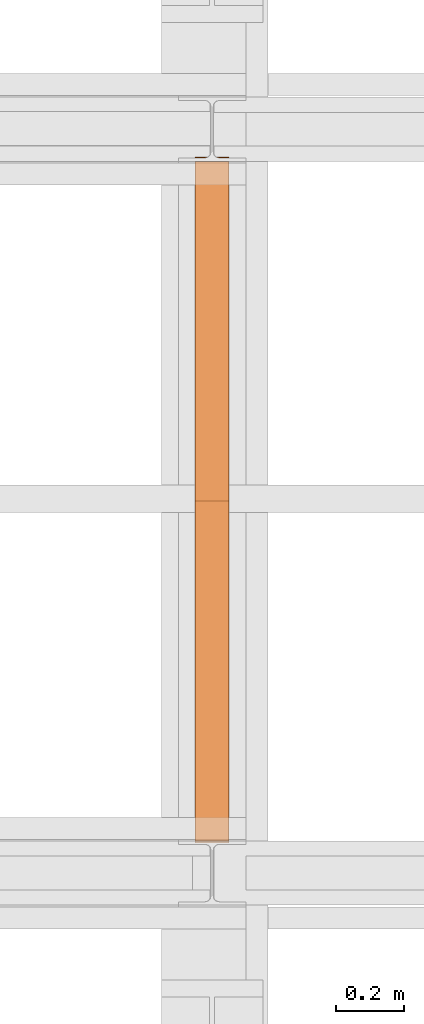
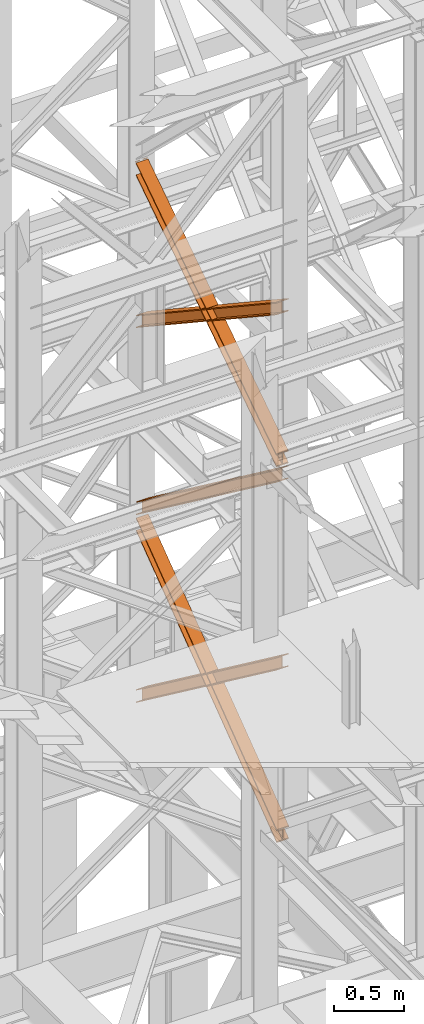
# One storey, part 122 of 208: 5 proxies.
"""IFC2X3 building model written with IfcOpenShell, lengths in millimetres."""

from ifc_helpers import new_model, entity, si_unit, converted_unit, frame, origin, origin_with_axes, place, context, subcontext, project, spatial, faceted_brep, element, save


model = new_model("IFC2X3")

# Units and contexts
model_context = context("Model", 3, precision=1e-05, world=origin())
plan_context = context("Plan", 3, precision=1e-05, world=origin())
body_context = subcontext(model_context, "Body", "Model", "MODEL_VIEW")
ifc_project = project(units=[si_unit("LENGTHUNIT", "METRE", prefix="MILLI"), converted_unit("PLANEANGLEUNIT", "DEGREE", entity("IfcPlaneAngleMeasure", 0.0174532925199433), si_unit("PLANEANGLEUNIT", "RADIAN"), dimensions=[0, 0, 0, 0, 0, 0, 0]), si_unit("AREAUNIT", "SQUARE_METRE"), si_unit("VOLUMEUNIT", "CUBIC_METRE")], contexts=[model_context, plan_context])

# Building, storey
building_placement = place(None, origin())
building = spatial("IfcBuilding", under=ifc_project, at=building_placement, CompositionType="COMPLEX")
storey_placement = place(building_placement, origin_with_axes())
storey = spatial("IfcBuildingStorey", under=building, at=storey_placement, Name="Geschoss", CompositionType="ELEMENT")

# Proxies
proxy_1_placement = place(storey_placement, frame((2142.708285590094, -15867.5743840594, 8785.68637815495), z_axis=(0.0, 0.0, 1.0), x_axis=(1.0, 0.0, 0.0)))
element("IfcBuildingElementProxy", 1, at=proxy_1_placement, inside=storey, context=body_context, shape_type="Brep", body=[
    faceted_brep([(100.0233329519015, 2010.009987483023, 1330.225167941017), (100.1729351296908, 0.00999999999839929, 0.02100513656660041), (100.1718996660056, 0.00999999999839929, 9.435622162609434), (100.0222968606722, 2010.009987483023, 1339.639782821612), (0.0233335574685043, 2010.009987483023, 1330.214162804454), (0.1729357352560328, 0.00999999999839929, 0.01000000000021828), (100.1729351296908, 0.00999999999839929, 0.02100513656660041), (100.0233329519015, 2010.009987483023, 1330.225167941017), (0.02229746624107065, 2010.009987483023, 1339.628777685057), (0.1719002715708484, 0.00999999999839929, 9.424617026043052), (0.1729357352560328, 0.00999999999839929, 0.01000000000021828), (0.0233335574685043, 2010.009987483023, 1330.214162804454), (47.52229717859518, 2010.009987483023, 1339.634005124923), (47.67189998392678, 0.00999999999839929, 9.429844465905262), (0.1719002715708484, 0.00999999999839929, 9.424617026043052), (0.02229746624107065, 2010.009987483023, 1339.628777685057), (47.5119362662881, 2010.009987483023, 1433.780153930935), (47.66154536059003, 0.00999999999839929, 103.5760147725105), (47.67189998392678, 0.00999999999839929, 9.429844465905262), (47.52229717859518, 2010.009987483023, 1339.634005124923), (0.01106478197652905, 2021.979642245309, 1441.696427017001), (0.01120823570636276, 2020.00998539686, 1440.39291091142), (29.30668085241086, 2020.00998539686, 1440.396134918205), (38.62249288135536, 2021.874530444144, 1441.631113415808), (38.72760466098953, 2021.979642245309, 1441.70068782511), (47.5119362662881, 2010.009987483023, 1433.780153930935), (0.01193655393217341, 2010.009987483023, 1433.774926491073), (0.161545648234096, 0.00999999999839929, 103.5707873326446), (47.66154536059003, 0.00999999999839929, 103.5760147725105), (0.01000000000021828, 2022.373573614999, 1451.371745118717), (0.01017214447529113, 2020.00998539686, 1449.807525792019), (0.01120823570636276, 2020.00998539686, 1440.39291091142), (0.01106478197652905, 2021.979642245309, 1441.696427017001), (0.01193655393217341, 2010.009987483023, 1433.774926491073), (0.01090046270292078, 2010.009987483023, 1443.189541371672), (0.1605101872537489, 0.00999999999839929, 112.9854043679352), (0.161545648234096, 0.00999999999839929, 103.5707873326446), (100.0099993944386, 2022.373573614997, 1451.382750255283), (100.0101715389137, 2020.00998539686, 1449.818530928586), (71.806685024736, 2020.00998539686, 1449.815427096359), (62.49087299579151, 2021.874530444144, 1451.048355158282), (61.99182992716487, 2022.373573614999, 1451.378566303787), (0.01090046270292078, 2010.009987483023, 1443.189541371672), (100.0108998571395, 2010.009987483023, 1443.200546508238), (100.1605095816922, 0.00999999999839929, 112.9964095044979), (0.1605101872537489, 0.00999999999839929, 112.9854043679352), (0.01017214447529113, 2020.00998539686, 1449.807525792019), (0.01000000000021828, 2022.373573614999, 1451.371745118717), (39.12153594998017, 2022.373573614999, 1451.376049396686), (38.62249288135536, 2021.874530444144, 1451.045728410436), (29.30668085241086, 2020.00998539686, 1449.810749912833), (100.0110641764131, 2021.979642245307, 1441.707432153557), (100.0112076301411, 2020.00998539686, 1440.403916047975), (100.0101715389137, 2020.00998539686, 1449.818530928586), (100.0099993944386, 2022.373573614997, 1451.382750255283), (100.0108998571395, 2010.009987483023, 1443.200546508238), (100.0119359483706, 2010.009987483023, 1433.785931627628), (100.1615450426671, 0.00999999999839929, 103.5817924692037), (100.1605095816922, 0.00999999999839929, 112.9964095044979), (52.51193623601102, 2010.009987483023, 1433.780704187766), (52.66154533031295, 0.00999999999839929, 103.5765650293379), (100.1615450426671, 0.00999999999839929, 103.5817924692037), (100.0119359483706, 2010.009987483023, 1433.785931627628), (71.806685024736, 2020.00998539686, 1440.400812101727), (100.0112076301411, 2020.00998539686, 1440.403916047975), (100.0110641764131, 2021.979642245307, 1441.707432153557), (62.38576121615733, 2021.979642245309, 1441.703291437565), (62.49087299579151, 2021.874530444144, 1441.63374016365), (52.52229714831447, 2010.009987483023, 1339.63455538175), (52.67189995364788, 0.00999999999839929, 9.43039472273631), (52.66154533031295, 0.00999999999839929, 103.5765650293379), (52.51193623601102, 2010.009987483023, 1433.780704187766), (100.0222968606722, 2010.009987483023, 1339.639782821612), (100.1718996660056, 0.00999999999839929, 9.435622162609434), (52.67189995364788, 0.00999999999839929, 9.43039472273631), (52.52229714831447, 2010.009987483023, 1339.63455538175), (62.38576121615733, 2021.979642245309, 1441.703291437565), (100.0110641764131, 2021.979642245307, 1441.707432153557), (100.0099993944386, 2022.373573614997, 1451.382750255283), (61.99182992716487, 2022.373573614999, 1451.378566303787), (39.12153594998017, 2022.373573614999, 1451.376049396686), (0.01000000000021828, 2022.373573614999, 1451.371745118717), (0.01106478197652905, 2021.979642245309, 1441.696427017001), (38.72760466098953, 2021.979642245309, 1441.70068782511), (62.49087299579151, 2021.874530444144, 1441.63374016365), (62.38576121615733, 2021.979642245309, 1441.703291437565), (61.99182992716487, 2022.373573614999, 1451.378566303787), (62.49087299579151, 2021.874530444144, 1451.048355158282), (62.49087299579151, 2021.874530444144, 1451.048355158282), (71.806685024736, 2020.00998539686, 1449.815427096359), (71.806685024736, 2020.00998539686, 1440.400812101727), (62.49087299579151, 2021.874530444144, 1441.63374016365), (71.806685024736, 2020.00998539686, 1449.815427096359), (100.0101715389137, 2020.00998539686, 1449.818530928586), (100.0112076301411, 2020.00998539686, 1440.403916047975), (71.806685024736, 2020.00998539686, 1440.400812101727), (100.0222968606722, 2010.009987483023, 1339.639782821612), (52.52229714831447, 2010.009987483023, 1339.63455538175), (52.51193623601102, 2010.009987483023, 1433.780704187766), (100.0119359483706, 2010.009987483023, 1433.785931627628), (100.0108998571395, 2010.009987483023, 1443.200546508238), (0.01090046270292078, 2010.009987483023, 1443.189541371672), (0.01193655393217341, 2010.009987483023, 1433.774926491073), (47.5119362662881, 2010.009987483023, 1433.780153930935), (47.52229717859518, 2010.009987483023, 1339.634005124923), (0.02229746624107065, 2010.009987483023, 1339.628777685057), (0.0233335574685043, 2010.009987483023, 1330.214162804454), (100.0233329519015, 2010.009987483023, 1330.225167941017), (29.30668085241086, 2020.00998539686, 1440.396134918205), (0.01120823570636276, 2020.00998539686, 1440.39291091142), (0.01017214447529113, 2020.00998539686, 1449.807525792019), (29.30668085241086, 2020.00998539686, 1449.810749912833), (29.30668085241086, 2020.00998539686, 1449.810749912833), (38.62249288135536, 2021.874530444144, 1451.045728410436), (38.62249288135536, 2021.874530444144, 1441.631113415808), (29.30668085241086, 2020.00998539686, 1440.396134918205), (38.62249288135536, 2021.874530444144, 1451.045728410436), (39.12153594998017, 2022.373573614999, 1451.376049396686), (38.72760466098953, 2021.979642245309, 1441.70068782511), (38.62249288135536, 2021.874530444144, 1441.631113415808), (100.1729351296908, 0.00999999999839929, 0.02100513656660041), (0.1729357352560328, 0.00999999999839929, 0.01000000000021828), (0.1719002715708484, 0.00999999999839929, 9.424617026043052), (47.67189998392678, 0.00999999999839929, 9.429844465905262), (47.66154536059003, 0.00999999999839929, 103.5760147725105), (0.161545648234096, 0.00999999999839929, 103.5707873326446), (0.1605101872537489, 0.00999999999839929, 112.9854043679352), (100.1605095816922, 0.00999999999839929, 112.9964095044979), (100.1615450426671, 0.00999999999839929, 103.5817924692037), (52.66154533031295, 0.00999999999839929, 103.5765650293379), (52.67189995364788, 0.00999999999839929, 9.43039472273631), (100.1718996660056, 0.00999999999839929, 9.435622162609434)], [[[0, 1, 2, 3]], [[4, 5, 6, 7]], [[8, 9, 10, 11]], [[12, 13, 14, 15]], [[16, 17, 18, 19]], [[20, 21, 22, 23, 24]], [[25, 26, 27, 28]], [[29, 30, 31, 32]], [[33, 34, 35, 36]], [[37, 38, 39, 40, 41]], [[42, 43, 44, 45]], [[46, 47, 48, 49, 50]], [[51, 52, 53, 54]], [[55, 56, 57, 58]], [[59, 60, 61, 62]], [[63, 64, 65, 66, 67]], [[68, 69, 70, 71]], [[72, 73, 74, 75]], [[76, 77, 78, 79]], [[80, 81, 82, 83]], [[84, 85, 86, 87]], [[88, 89, 90, 91]], [[92, 93, 94, 95]], [[96, 97, 98, 99, 100, 101, 102, 103, 104, 105, 106, 107]], [[108, 109, 110, 111]], [[112, 113, 114, 115]], [[116, 117, 118, 119]], [[120, 121, 122, 123, 124, 125, 126, 127, 128, 129, 130, 131]]], orient=[[False], [False], [False], [False], [False], [False], [False], [False], [False], [False], [False], [False], [False], [False], [False], [False], [False], [False], [False], [False], [False], [False], [False], [False], [False], [False], [False], [False]]),
])
proxy_2_placement = place(storey_placement, frame((2142.717760907841, -15867.5743840594, 8785.050753356181), z_axis=(0.0, 0.0, 1.0), x_axis=(1.0, 0.0, 0.0)))
element("IfcBuildingElementProxy", 2, at=proxy_2_placement, inside=storey, context=body_context, shape_type="Brep", body=[
    faceted_brep([(100.0213960296205, 0.01000000000021828, 1340.168495796863), (100.1712583843328, 2010.009987483025, 9.436734304987112), (100.1722939377632, 2010.009987483025, 0.02100513655932446), (100.0224320873658, 0.01000000000021828, 1330.752768748162), (100.0224320873658, 0.01000000000021828, 1330.752768748162), (100.1722939377632, 2010.009987483025, 0.02100513655932446), (0.1722945433284622, 2010.009987483025, 0.01000000000021828), (0.02243269293285266, 0.01000000000021828, 1330.741763611606), (0.02243269293285266, 0.01000000000021828, 1330.741763611606), (0.1722945433284622, 2010.009987483025, 0.01000000000021828), (0.1712589898997976, 2010.009987483025, 9.425729168431644), (0.02139663518937596, 0.01000000000021828, 1340.1574906603), (0.02139663518937596, 0.01000000000021828, 1340.1574906603), (0.1712589898997976, 2010.009987483025, 9.425729168431644), (47.67125870225755, 2010.009987483025, 9.430956608297492), (47.52139634754713, 0.01000000000021828, 1340.162718100166), (47.52139634754713, 0.01000000000021828, 1340.162718100166), (47.67125870225755, 2010.009987483025, 9.430956608297492), (47.66090317872477, 2010.009987483025, 103.5882483377918), (47.51103577010144, 0.01000000000021828, 1434.319988587145), (47.51103577010144, 0.01000000000021828, 1434.319988587145), (47.66090317872477, 2010.009987483025, 103.5882483377918), (0.1609034663688362, 2010.009987483025, 103.583020897926), (0.01103605774551397, 0.01000000000021828, 1434.31476114728), (0.01103605774551397, 0.01000000000021828, 1434.31476114728), (0.1609034663688362, 2010.009987483025, 103.583020897926), (0.1598679150920361, 2010.009987483025, 112.998750075405), (0.01000000000021828, 0.01000000000021828, 1443.730488195981), (0.01000000000021828, 0.01000000000021828, 1443.730488195981), (0.1598679150920361, 2010.009987483025, 112.998750075405), (100.159867309525, 2010.009987483025, 113.0097552119678), (100.009999394435, 0.01000000000021828, 1443.741493332544), (100.009999394435, 0.01000000000021828, 1443.741493332544), (100.159867309525, 2010.009987483025, 113.0097552119678), (100.1609028608018, 2010.009987483025, 103.5940260344851), (100.0110354521785, 0.01000000000021828, 1434.325766283846), (100.0110354521785, 0.01000000000021828, 1434.325766283846), (100.1609028608018, 2010.009987483025, 103.5940260344851), (52.66090314844587, 2010.009987483025, 103.5887985946229), (52.51103573982437, 0.01000000000021828, 1434.320538843973), (52.51103573982437, 0.01000000000021828, 1434.320538843973), (52.66090314844587, 2010.009987483025, 103.5887985946229), (52.67125867197683, 2010.009987483025, 9.431506865121264), (52.52139631726823, 0.01000000000021828, 1340.163268357001), (52.52139631726823, 0.01000000000021828, 1340.163268357001), (52.67125867197683, 2010.009987483025, 9.431506865121264), (100.1712583843328, 2010.009987483025, 9.436734304987112), (100.0213960296205, 0.01000000000021828, 1340.168495796863), (100.0224320873658, 0.01000000000021828, 1330.752768748162), (0.02243269293285266, 0.01000000000021828, 1330.741763611606), (0.02139663518937596, 0.01000000000021828, 1340.1574906603), (47.52139634754713, 0.01000000000021828, 1340.162718100166), (47.51103577010144, 0.01000000000021828, 1434.319988587145), (0.01103605774551397, 0.01000000000021828, 1434.31476114728), (0.01000000000021828, 0.01000000000021828, 1443.730488195981), (100.009999394435, 0.01000000000021828, 1443.741493332544), (100.0110354521785, 0.01000000000021828, 1434.325766283846), (52.51103573982437, 0.01000000000021828, 1434.320538843973), (52.52139631726823, 0.01000000000021828, 1340.163268357001), (100.0213960296205, 0.01000000000021828, 1340.168495796863), (100.1712583843328, 2010.009987483025, 9.436734304987112), (52.67125867197683, 2010.009987483025, 9.431506865121264), (52.66090314844587, 2010.009987483025, 103.5887985946229), (100.1609028608018, 2010.009987483025, 103.5940260344851), (100.159867309525, 2010.009987483025, 113.0097552119678), (0.1598679150920361, 2010.009987483025, 112.998750075405), (0.1609034663688362, 2010.009987483025, 103.583020897926), (47.66090317872477, 2010.009987483025, 103.5882483377918), (47.67125870225755, 2010.009987483025, 9.430956608297492), (0.1712589898997976, 2010.009987483025, 9.425729168431644), (0.1722945433284622, 2010.009987483025, 0.01000000000021828), (100.1722939377632, 2010.009987483025, 0.02100513655932446)], [[[0, 1, 2, 3]], [[4, 5, 6, 7]], [[8, 9, 10, 11]], [[12, 13, 14, 15]], [[16, 17, 18, 19]], [[20, 21, 22, 23]], [[24, 25, 26, 27]], [[28, 29, 30, 31]], [[32, 33, 34, 35]], [[36, 37, 38, 39]], [[40, 41, 42, 43]], [[44, 45, 46, 47]], [[48, 49, 50, 51, 52, 53, 54, 55, 56, 57, 58, 59]], [[60, 61, 62, 63, 64, 65, 66, 67, 68, 69, 70, 71]]], orient=[[False], [False], [False], [False], [False], [False], [False], [False], [False], [False], [False], [False], [False], [False]]),
])
proxy_3_placement = place(storey_placement, frame((2143.082798491103, -15873.1965123697, 5499.689768811883), z_axis=(0.0, 0.0, 1.0), x_axis=(1.0, 0.0, 0.0)))
element("IfcBuildingElementProxy", 3, at=proxy_3_placement, inside=storey, context=body_context, shape_type="Brep", body=[
    faceted_brep([(100.0229428112289, 2015.632115793322, 1505.703241650141), (100.1858455764686, 1.953628280809426, 0.02100513656296243), (100.1847800613887, 1.791659257409265, 9.702984703128095), (100.0218641931642, 2015.632115793322, 1515.50632986583), (0.02294341679771605, 2015.632115793322, 1505.692236513578), (0.1858461820338562, 1.953628280809426, 0.01000000000021828), (100.1858455764686, 1.953628280809426, 0.02100513656296243), (100.0229428112289, 2015.632115793322, 1505.703241650141), (0.02186479873125791, 2015.632115793322, 1515.495324729271), (0.1847806669538841, 1.791659257407446, 9.691979566568989), (0.1858461820338562, 1.953628280809426, 0.01000000000021828), (0.02294341679771605, 2015.632115793322, 1505.692236513578), (47.52186451108355, 2015.632115793322, 1515.500552169136), (47.68478037930981, 1.791659257407446, 9.697207006434837), (0.1847806669538841, 1.791659257407446, 9.691979566568989), (0.02186479873125791, 2015.632115793322, 1515.495324729271), (47.51107833042624, 2015.632115793322, 1613.531434326045), (47.67412522851737, 0.1719690234003792, 106.517002672068), (47.68478037930981, 1.791659257407446, 9.697207006434837), (47.52186451108355, 2015.632115793322, 1515.500552169136), (0.01107861806849542, 2015.632115793322, 1613.526206886179), (0.174125516157801, 0.1719690234003792, 106.5117752322021), (47.67412522851737, 0.1719690234003792, 106.517002672068), (47.51107833042624, 2015.632115793322, 1613.531434326045), (0.01000000000021828, 2015.632115793322, 1623.329295101868), (0.1730600010778289, 0.01000000000021828, 116.1937547987636), (0.174125516157801, 0.1719690234003792, 106.5117752322021), (0.01107861806849542, 2015.632115793322, 1613.526206886179), (100.0099993944386, 2015.632115793322, 1623.340300238435), (100.1730593955126, 0.01000000000203727, 116.2047599353264), (0.1730600010778289, 0.01000000000021828, 116.1937547987636), (0.01000000000021828, 2015.632115793322, 1623.329295101868), (100.0110780125051, 2015.632115793322, 1613.537212022739), (100.1741249105908, 0.1719690234003792, 106.5227803687612), (100.1730593955126, 0.01000000000203727, 116.2047599353264), (100.0099993944386, 2015.632115793322, 1623.340300238435), (52.51107830014917, 2015.632115793322, 1613.531984582873), (52.67412519823665, 0.1719690234003792, 106.5175529288954), (100.1741249105908, 0.1719690234003792, 106.5227803687612), (100.0110780125051, 2015.632115793322, 1613.537212022739), (52.52186448080829, 2015.632115793322, 1515.501102425964), (52.68478034903274, 1.791659257409265, 9.697757263262247), (52.67412519823665, 0.1719690234003792, 106.5175529288954), (52.51107830014917, 2015.632115793322, 1613.531984582873), (100.0218641931642, 2015.632115793322, 1515.50632986583), (100.1847800613887, 1.791659257409265, 9.702984703128095), (52.68478034903274, 1.791659257409265, 9.697757263262247), (52.52186448080829, 2015.632115793322, 1515.501102425964), (100.1858455764686, 1.953628280809426, 0.02100513656296243), (0.1858461820338562, 1.953628280809426, 0.01000000000021828), (0.1847806669538841, 1.791659257407446, 9.691979566568989), (47.68478037930981, 1.791659257407446, 9.697207006434837), (47.67412522851737, 0.1719690234003792, 106.517002672068), (0.174125516157801, 0.1719690234003792, 106.5117752322021), (0.1730600010778289, 0.01000000000021828, 116.1937547987636), (100.1730593955126, 0.01000000000203727, 116.2047599353264), (100.1741249105908, 0.1719690234003792, 106.5227803687612), (52.67412519823665, 0.1719690234003792, 106.5175529288954), (52.68478034903274, 1.791659257409265, 9.697757263262247), (100.1847800613887, 1.791659257409265, 9.702984703128095), (100.0218641931642, 2015.632115793322, 1515.50632986583), (52.52186448080829, 2015.632115793322, 1515.501102425964), (52.51107830014917, 2015.632115793322, 1613.531984582873), (100.0110780125051, 2015.632115793322, 1613.537212022739), (100.0099993944386, 2015.632115793322, 1623.340300238435), (0.01000000000021828, 2015.632115793322, 1623.329295101868), (0.01107861806849542, 2015.632115793322, 1613.526206886179), (47.51107833042624, 2015.632115793322, 1613.531434326045), (47.52186451108355, 2015.632115793322, 1515.500552169136), (0.02186479873125791, 2015.632115793322, 1515.495324729271), (0.02294341679771605, 2015.632115793322, 1505.692236513578), (100.0229428112289, 2015.632115793322, 1505.703241650141)], [[[0, 1, 2, 3]], [[4, 5, 6, 7]], [[8, 9, 10, 11]], [[12, 13, 14, 15]], [[16, 17, 18, 19]], [[20, 21, 22, 23]], [[24, 25, 26, 27]], [[28, 29, 30, 31]], [[32, 33, 34, 35]], [[36, 37, 38, 39]], [[40, 41, 42, 43]], [[44, 45, 46, 47]], [[48, 49, 50, 51, 52, 53, 54, 55, 56, 57, 58, 59]], [[60, 61, 62, 63, 64, 65, 66, 67, 68, 69, 70, 71]]], orient=[[False], [False], [False], [False], [False], [False], [False], [False], [False], [False], [False], [False], [False], [False]]),
])
proxy_4_placement = place(storey_placement, frame((2143.082676642578, -15867.5743840594, 5504.219540188055), z_axis=(0.0, 0.0, 1.0), x_axis=(1.0, 0.0, 0.0)))
element("IfcBuildingElementProxy", 4, at=proxy_4_placement, inside=storey, context=body_context, shape_type="Brep", body=[
    faceted_brep([(100.0218596475406, 0.01000000000021828, 1511.076608371926), (100.1844513161013, 2010.009987483025, 9.820176864343011), (100.1855295209298, 2010.009987483025, 0.02100513655932446), (100.0229378523673, 0.01000000000021828, 1501.277436644132), (100.0229378523673, 0.01000000000021828, 1501.277436644132), (100.1855295209298, 2010.009987483025, 0.02100513655932446), (0.1855301264913578, 2010.009987483025, 0.01000000000021828), (0.02293845793246874, 0.01000000000021828, 1501.266431507576), (0.02293845793246874, 0.01000000000021828, 1501.266431507576), (0.1855301264913578, 2010.009987483025, 0.01000000000021828), (0.1844519216665503, 2010.009987483025, 9.809171727787543), (0.02186025310402329, 0.01000000000021828, 1511.06560323536), (0.02186025310402329, 0.01000000000021828, 1511.06560323536), (0.1844519216665503, 2010.009987483025, 9.809171727787543), (47.6844516340243, 2010.009987483025, 9.814399167646116), (47.52185996546359, 0.01000000000021828, 1511.070830675226), (47.52185996546359, 0.01000000000021828, 1511.070830675226), (47.6844516340243, 2010.009987483025, 9.814399167646116), (47.6736695857453, 2010.009987483025, 107.8061164454975), (47.51107791718459, 0.01000000000021828, 1609.062547953077), (47.51107791718459, 0.01000000000021828, 1609.062547953077), (47.6736695857453, 2010.009987483025, 107.8061164454975), (0.1736698733893718, 2010.009987483025, 107.8008890056317), (0.01107820482866373, 0.01000000000021828, 1609.057320513211), (0.01107820482866373, 0.01000000000021828, 1609.057320513211), (0.1736698733893718, 2010.009987483025, 107.8008890056317), (0.1725916685609263, 2010.009987483025, 117.6000607334227), (0.01000000000021828, 0.01000000000021828, 1618.856492240995), (0.01000000000021828, 0.01000000000021828, 1618.856492240995), (0.1725916685609263, 2010.009987483025, 117.6000607334227), (100.1725910629975, 2010.009987483025, 117.6110658699781), (100.009999394435, 0.01000000000021828, 1618.867497377558), (100.009999394435, 0.01000000000021828, 1618.867497377558), (100.1725910629975, 2010.009987483025, 117.6110658699781), (100.1736692678242, 2010.009987483025, 107.8118941421981), (100.0110775992634, 0.01000000000021828, 1609.068325649774), (100.0110775992634, 0.01000000000021828, 1609.068325649774), (100.1736692678242, 2010.009987483025, 107.8118941421981), (52.67366955546459, 2010.009987483025, 107.806666702325), (52.51107788690388, 0.01000000000021828, 1609.063098209905), (52.51107788690388, 0.01000000000021828, 1609.063098209905), (52.67366955546459, 2010.009987483025, 107.806666702325), (52.6844516037454, 2010.009987483025, 9.814949424477163), (52.52185993518287, 0.01000000000021828, 1511.071380932057), (52.52185993518287, 0.01000000000021828, 1511.071380932057), (52.6844516037454, 2010.009987483025, 9.814949424477163), (100.1844513161013, 2010.009987483025, 9.820176864343011), (100.0218596475406, 0.01000000000021828, 1511.076608371926), (100.1844513161013, 2010.009987483025, 9.820176864343011), (52.6844516037454, 2010.009987483025, 9.814949424477163), (52.67366955546459, 2010.009987483025, 107.806666702325), (100.1736692678242, 2010.009987483025, 107.8118941421981), (100.1725910629975, 2010.009987483025, 117.6110658699781), (0.1725916685609263, 2010.009987483025, 117.6000607334227), (0.1736698733893718, 2010.009987483025, 107.8008890056317), (47.6736695857453, 2010.009987483025, 107.8061164454975), (47.6844516340243, 2010.009987483025, 9.814399167646116), (0.1844519216665503, 2010.009987483025, 9.809171727787543), (0.1855301264913578, 2010.009987483025, 0.01000000000021828), (100.1855295209298, 2010.009987483025, 0.02100513655932446), (100.0229378523673, 0.01000000000021828, 1501.277436644132), (0.02293845793246874, 0.01000000000021828, 1501.266431507576), (0.02186025310402329, 0.01000000000021828, 1511.06560323536), (47.52185996546359, 0.01000000000021828, 1511.070830675226), (47.51107791718459, 0.01000000000021828, 1609.062547953077), (0.01107820482866373, 0.01000000000021828, 1609.057320513211), (0.01000000000021828, 0.01000000000021828, 1618.856492240995), (100.009999394435, 0.01000000000021828, 1618.867497377558), (100.0110775992634, 0.01000000000021828, 1609.068325649774), (52.51107788690388, 0.01000000000021828, 1609.063098209905), (52.52185993518287, 0.01000000000021828, 1511.071380932057), (100.0218596475406, 0.01000000000021828, 1511.076608371926)], [[[0, 1, 2, 3]], [[4, 5, 6, 7]], [[8, 9, 10, 11]], [[12, 13, 14, 15]], [[16, 17, 18, 19]], [[20, 21, 22, 23]], [[24, 25, 26, 27]], [[28, 29, 30, 31]], [[32, 33, 34, 35]], [[36, 37, 38, 39]], [[40, 41, 42, 43]], [[44, 45, 46, 47]], [[48, 49, 50, 51, 52, 53, 54, 55, 56, 57, 58, 59]], [[60, 61, 62, 63, 64, 65, 66, 67, 68, 69, 70, 71]]], orient=[[False], [False], [False], [False], [False], [False], [False], [False], [False], [False], [False], [False], [False], [False]]),
])
proxy_5_placement = place(storey_placement, frame((2142.895475356376, -15867.5743840594, 7147.441290649187), z_axis=(0.0, 0.0, 1.0), x_axis=(1.0, 0.0, 0.0)))
element("IfcBuildingElementProxy", 5, at=proxy_5_placement, inside=storey, context=body_context, shape_type="Brep", body=[
    faceted_brep([(100.0218623025612, 0.01000000000021828, 1512.063556389601), (100.1844166626906, 2010.009987483025, 9.822513400360549), (100.1854951088862, 2010.009987483025, 0.02100513655932446), (100.022940748755, 0.01000000000021828, 1502.262048125804), (100.022940748755, 0.01000000000021828, 1502.262048125804), (100.1854951088862, 2010.009987483025, 0.02100513655932446), (0.1854957144514629, 2010.009987483025, 0.01000000000021828), (0.02294135431839095, 0.01000000000021828, 1502.251042989237), (0.02294135431839095, 0.01000000000021828, 1502.251042989237), (0.1854957144514629, 2010.009987483025, 0.01000000000021828), (0.1844172682558565, 2010.009987483025, 9.811508263797805), (0.02186290812642255, 0.01000000000021828, 1512.052551253039), (0.02186290812642255, 0.01000000000021828, 1512.052551253039), (0.1844172682558565, 2010.009987483025, 9.811508263797805), (47.68441698061361, 2010.009987483025, 9.816735703663653), (47.52186262048235, 0.01000000000021828, 1512.057778692908), (47.52186262048235, 0.01000000000021828, 1512.057778692908), (47.68441698061361, 2010.009987483025, 9.816735703663653), (47.67363251868483, 2010.009987483025, 107.8318183416577), (47.51107815855175, 0.01000000000021828, 1610.072861330906), (47.51107815855175, 0.01000000000021828, 1610.072861330906), (47.67363251868483, 2010.009987483025, 107.8318183416577), (0.1736328063252586, 2010.009987483025, 107.8265909017955), (0.01107844619582465, 0.01000000000021828, 1610.067633891033), (0.01107844619582465, 0.01000000000021828, 1610.067633891033), (0.1736328063252586, 2010.009987483025, 107.8265909017955), (0.1725543601314712, 2010.009987483025, 117.6280991655931), (0.01000000000021828, 0.01000000000021828, 1619.86914215483), (0.01000000000021828, 0.01000000000021828, 1619.86914215483), (0.1725543601314712, 2010.009987483025, 117.6280991655931), (100.1725537545663, 2010.009987483025, 117.6391043021558), (100.009999394435, 0.01000000000021828, 1619.880147291397), (100.009999394435, 0.01000000000021828, 1619.880147291397), (100.1725537545663, 2010.009987483025, 117.6391043021558), (100.1736322007619, 2010.009987483025, 107.8375960383546), (100.0110778406306, 0.01000000000021828, 1610.078639027603), (100.0110778406306, 0.01000000000021828, 1610.078639027603), (100.1736322007619, 2010.009987483025, 107.8375960383546), (52.67363248840411, 2010.009987483025, 107.8323685984888), (52.51107812827468, 0.01000000000021828, 1610.073411587733), (52.51107812827468, 0.01000000000021828, 1610.073411587733), (52.67363248840411, 2010.009987483025, 107.8323685984888), (52.68441695033471, 2010.009987483025, 9.817285960491063), (52.52186259020346, 0.01000000000021828, 1512.058328949732), (52.52186259020346, 0.01000000000021828, 1512.058328949732), (52.68441695033471, 2010.009987483025, 9.817285960491063), (100.1844166626906, 2010.009987483025, 9.822513400360549), (100.0218623025612, 0.01000000000021828, 1512.063556389601), (100.1844166626906, 2010.009987483025, 9.822513400360549), (52.68441695033471, 2010.009987483025, 9.817285960491063), (52.67363248840411, 2010.009987483025, 107.8323685984888), (100.1736322007619, 2010.009987483025, 107.8375960383546), (100.1725537545663, 2010.009987483025, 117.6391043021558), (0.1725543601314712, 2010.009987483025, 117.6280991655931), (0.1736328063252586, 2010.009987483025, 107.8265909017955), (47.67363251868483, 2010.009987483025, 107.8318183416577), (47.68441698061361, 2010.009987483025, 9.816735703663653), (0.1844172682558565, 2010.009987483025, 9.811508263797805), (0.1854957144514629, 2010.009987483025, 0.01000000000021828), (100.1854951088862, 2010.009987483025, 0.02100513655932446), (100.022940748755, 0.01000000000021828, 1502.262048125804), (0.02294135431839095, 0.01000000000021828, 1502.251042989237), (0.02186290812642255, 0.01000000000021828, 1512.052551253039), (47.52186262048235, 0.01000000000021828, 1512.057778692908), (47.51107815855175, 0.01000000000021828, 1610.072861330906), (0.01107844619582465, 0.01000000000021828, 1610.067633891033), (0.01000000000021828, 0.01000000000021828, 1619.86914215483), (100.009999394435, 0.01000000000021828, 1619.880147291397), (100.0110778406306, 0.01000000000021828, 1610.078639027603), (52.51107812827468, 0.01000000000021828, 1610.073411587733), (52.52186259020346, 0.01000000000021828, 1512.058328949732), (100.0218623025612, 0.01000000000021828, 1512.063556389601)], [[[0, 1, 2, 3]], [[4, 5, 6, 7]], [[8, 9, 10, 11]], [[12, 13, 14, 15]], [[16, 17, 18, 19]], [[20, 21, 22, 23]], [[24, 25, 26, 27]], [[28, 29, 30, 31]], [[32, 33, 34, 35]], [[36, 37, 38, 39]], [[40, 41, 42, 43]], [[44, 45, 46, 47]], [[48, 49, 50, 51, 52, 53, 54, 55, 56, 57, 58, 59]], [[60, 61, 62, 63, 64, 65, 66, 67, 68, 69, 70, 71]]], orient=[[False], [False], [False], [False], [False], [False], [False], [False], [False], [False], [False], [False], [False], [False]]),
])

save(model, "model.ifc")
